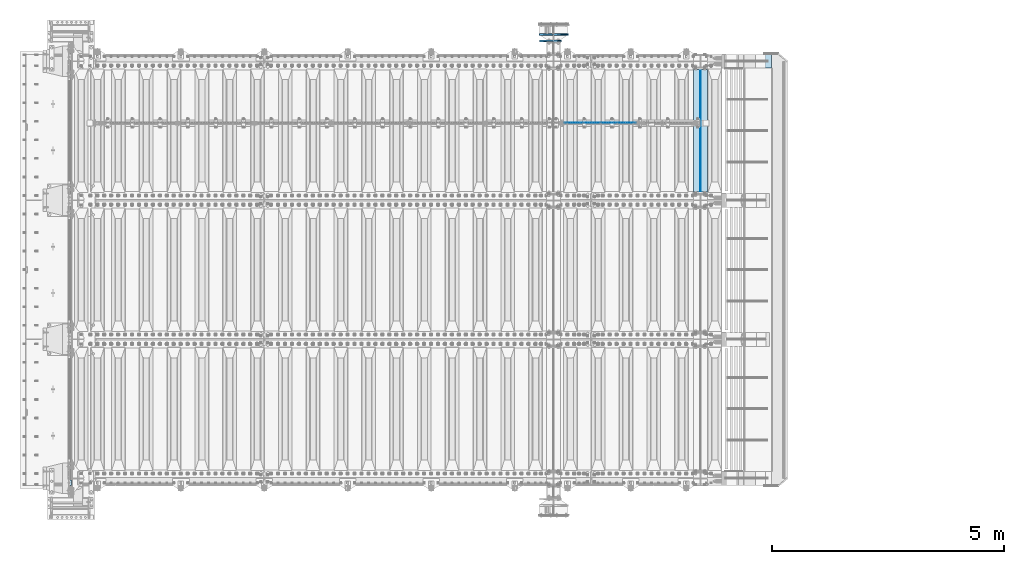
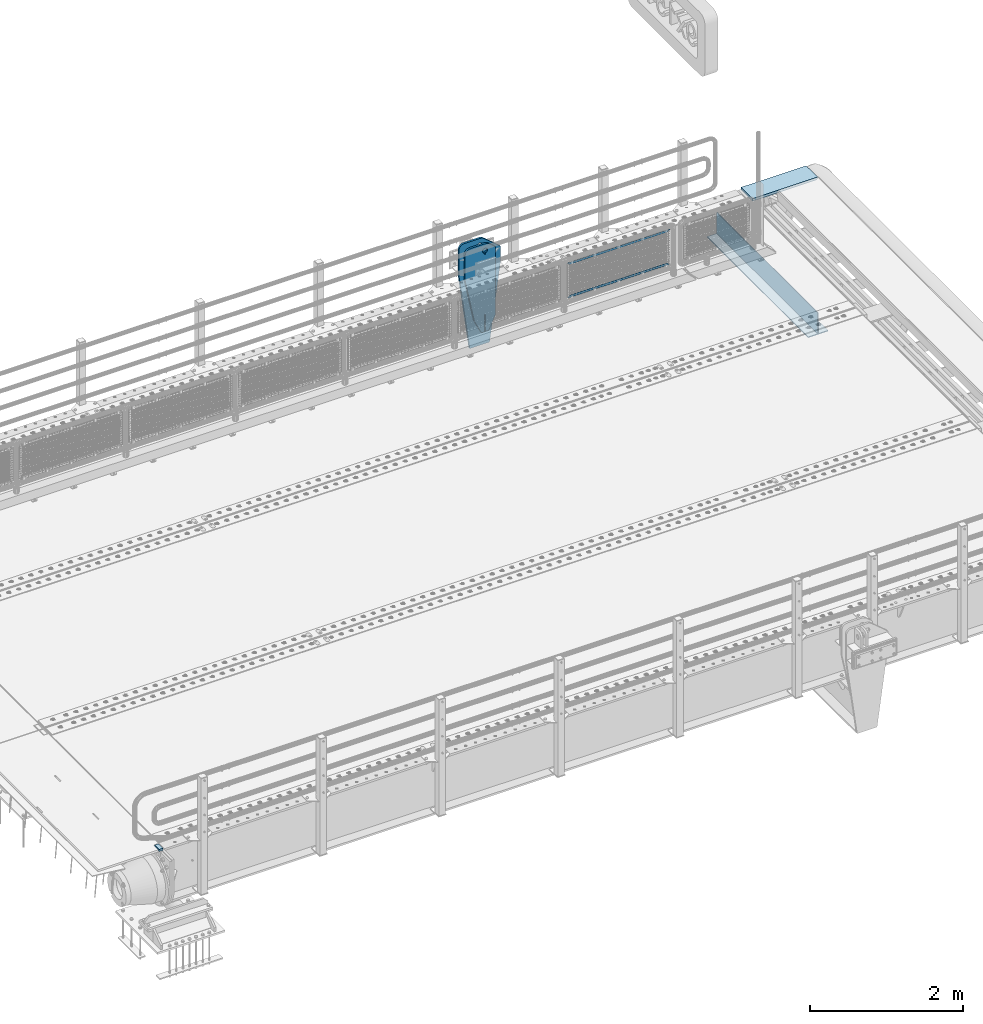
# One storey, part 173 of 219: 8 plates.
"""IFC2X3 building model written with IfcOpenShell, lengths in millimetres."""

from ifc_helpers import new_model, si_unit, frame, origin_with_axes, place, context, subcontext, project, spatial, faceted_brep, material, type_object, element, save


model = new_model("IFC2X3")

# Units and contexts
model_context = context("Model", 3, precision=1e-05, world=origin_with_axes())
body_context = subcontext(model_context, "Body", "Model", "MODEL_VIEW")
ifc_project = project(units=[si_unit("LENGTHUNIT", "METRE", prefix="MILLI"), si_unit("AREAUNIT", "SQUARE_METRE"), si_unit("VOLUMEUNIT", "CUBIC_METRE"), si_unit("MASSUNIT", "GRAM", prefix="KILO"), si_unit("TIMEUNIT", "SECOND"), si_unit("PLANEANGLEUNIT", "RADIAN"), si_unit("SOLIDANGLEUNIT", "STERADIAN"), si_unit("THERMODYNAMICTEMPERATUREUNIT", "DEGREE_CELSIUS"), si_unit("LUMINOUSINTENSITYUNIT", "LUMEN")], contexts=[model_context])

# Site, building, storey
site_placement = place(None, origin_with_axes())
site = spatial("IfcSite", under=ifc_project, at=site_placement, CompositionType="ELEMENT")
building_placement = place(site_placement, origin_with_axes())
building = spatial("IfcBuilding", under=site, at=building_placement, Name="Standard", CompositionType="ELEMENT")
storey_placement = place(building_placement, origin_with_axes())
storey = spatial("IfcBuildingStorey", under=building, at=storey_placement, Name="Undefined", CompositionType="ELEMENT", Elevation=0.0)

# Plates
ifc_material_1 = material()
plate_type_1 = type_object("IfcPlateType", PredefinedType="NOTDEFINED")
plate_1_placement = place(storey_placement, frame((-10.0000000601686, 23910.0000004317, -15.9997806106704), z_axis=(-1.0, 0.0, 0.0), x_axis=(0.0, -4.95099997756316e-06, 0.999999999987744)))
element("IfcPlate", 1, at=plate_1_placement, inside=storey, type_object=plate_type_1, material=ifc_material_1, context=body_context, shape_type="Brep", body=[
    faceted_brep([(0.0, -60.0, 0.0), (-0.000933120085687023, -60.0000000000036, 60.0), (-0.000933120085687023, 59.9999999999964, 60.0), (0.0, 60.0000000000036, 0.0), (24.9991450303709, -60.0, 60.0), (24.9991450303709, 59.9999999999964, 60.0), (26.544215218168, -60.0000000000036, 59.7552873850884), (26.544215218168, 60.0, 59.7552873850884), (27.9380461396139, -60.0000000000036, 59.0451032459123), (27.9380461396139, 60.0, 59.0451032459123), (29.0442025908961, -60.0000000000036, 57.9389639895784), (29.0442025908961, 60.0, 57.9389639895784), (29.7544083969366, -60.0, 56.5451441080361), (29.7544083969366, 60.0000000000036, 56.5451441080361), (29.9991450297669, -60.0000000000036, 55.0000777244568), (29.9991450297669, 60.0, 55.0000777244568), (29.999922274335, -60.0, 5.00007772445704), (29.999922274335, 60.0, 5.00007772445704), (29.7552240705896, -60.0000000000036, 3.45497416452589), (29.7552240705896, 60.0, 3.45497416452589), (29.0450346578116, -60.0, 2.06111146690959), (29.0450346578116, 59.9999999999964, 2.06111146690959), (27.9388736885072, -60.0, 0.954933302319514), (27.9388736885072, 59.9999999999964, 0.954933302319514), (26.5450220308766, -60.0000000000036, 0.244722222183089), (26.5450220308766, 60.0, 0.244722222183089), (24.9999222749392, -60.0, 2.64677169070637e-13), (24.9999222749392, 60.0, 2.66453525910038e-13)], [[[0, 1, 2, 3]], [[1, 4, 5, 2]], [[4, 6, 7, 5]], [[6, 8, 9, 7]], [[8, 10, 11, 9]], [[10, 12, 13, 11]], [[12, 14, 15, 13]], [[14, 16, 17, 15]], [[16, 18, 19, 17]], [[18, 20, 21, 19]], [[20, 22, 23, 21]], [[22, 24, 25, 23]], [[24, 26, 27, 25]], [[26, 0, 3, 27]], [[5, 7, 9, 11, 13, 15, 17, 19, 21, 23, 25, 27, 3, 2]], [[26, 24, 22, 20, 18, 16, 14, 12, 10, 8, 6, 4, 1, 0]]]),
])
ifc_material_2 = material(Name="STEEL/S355N")
plate_type_2 = type_object("IfcPlateType", PredefinedType="NOTDEFINED")
plate_2_placement = place(storey_placement, frame((13555.0, 32825.0, 0.0), z_axis=(0.0, 0.0, -1.0), x_axis=(0.0, -1.0, 0.0)))
element("IfcPlate", 2, at=plate_2_placement, inside=storey, type_object=plate_type_2, material=ifc_material_2, context=body_context, shape_type="Brep", body=[
    faceted_brep([(0.0, -5.0, 0.0), (0.0, -5.0, 336.0), (0.0, 5.0, 336.0), (0.0, 5.0, 0.0), (2650.0, -5.0, 336.0), (2650.0, 5.0, 336.0), (2650.0, -5.0, 0.0), (2650.0, 5.0, 0.0)], [[[0, 1, 2, 3]], [[1, 4, 5, 2]], [[4, 6, 7, 5]], [[6, 0, 3, 7]], [[5, 7, 3, 2]], [[6, 4, 1, 0]]]),
])
plate_type_3 = type_object("IfcPlateType", PredefinedType="NOTDEFINED")
plate_3_placement = place(storey_placement, frame((13405.0, 30175.0, -343.0), z_axis=(0.0, 1.0, 0.0), x_axis=(1.0, 0.0, 0.0)))
element("IfcPlate", 3, at=plate_3_placement, inside=storey, type_object=plate_type_3, material=ifc_material_2, context=body_context, shape_type="Brep", body=[
    faceted_brep([(0.0, -7.0, 0.0), (0.0, -7.0, 2650.0), (0.0, 7.0, 2650.0), (0.0, 7.0, 0.0), (300.0, -7.0, 2650.0), (300.0, 7.0, 2650.0), (300.0, -7.0, 0.0), (300.0, 7.0, 0.0)], [[[0, 1, 2, 3]], [[1, 4, 5, 2]], [[4, 6, 7, 5]], [[6, 0, 3, 7]], [[5, 7, 3, 2]], [[6, 4, 1, 0]]]),
])
ifc_material_3 = material(Name="Misc_Undefined")
plate_type_4 = type_object("IfcPlateType", PredefinedType="NOTDEFINED")
plate_4_placement = place(storey_placement, frame((10622.5050117304, 31670.5, 351.520303374641), z_axis=(0.0, 0.0, 1.0), x_axis=(1.0, 0.0, 0.0)))
element("IfcPlate", 4, at=plate_4_placement, inside=storey, type_object=plate_type_4, material=ifc_material_3, context=body_context, shape_type="Brep", body=[
    faceted_brep([(0.0, -1.5, -5.6843418860808e-14), (35.0002975463885, -1.5, 34.9996948242187), (35.0002975463885, 1.5, 34.9996948242187), (0.0, 1.5, -5.6843418860808e-14), (1515.99035644531, -1.5, 34.9999923706054), (1515.99035644531, 1.5, 34.9999923706054), (1550.98999023438, -1.5, 4.43037606601138e-09), (1550.98999023438, 1.5, 4.43037606601138e-09)], [[[0, 1, 2, 3]], [[1, 4, 5, 2]], [[4, 6, 7, 5]], [[6, 0, 3, 7]], [[5, 7, 3, 2]], [[6, 4, 1, 0]]]),
])
plate_5_placement = place(storey_placement, frame((12173.5000001876, 31670.5, 914.520000175701), z_axis=(-0.707103624179499, 0.0, 0.707109938179501), x_axis=(-0.707109938179508, 0.0, -0.707103624179492)))
element("IfcPlate", 5, at=plate_5_placement, inside=storey, type_object=plate_type_4, material=ifc_material_3, context=body_context, shape_type="Brep", body=[
    faceted_brep([(0.0, -1.5, -5.6843418860808e-14), (1096.72753906249, -1.5, 1096.7177734375), (1096.72753906249, 1.5, 1096.7177734375), (0.0, 1.5, -5.6843418860808e-14), (1096.72045898437, -1.5, 1047.21337890625), (1096.72045898437, 1.5, 1047.21337890625), (49.4976959228516, -1.5, -1.0550138540566e-10), (49.4976959228516, 1.5, -1.0550138540566e-10)], [[[0, 1, 2, 3]], [[1, 4, 5, 2]], [[4, 6, 7, 5]], [[6, 0, 3, 7]], [[5, 7, 3, 2]], [[6, 4, 1, 0]]]),
])
plate_type_5 = type_object("IfcPlateType", PredefinedType="NOTDEFINED")
plate_6_placement = place(storey_placement, frame((14106.9988298905, 33150.0, -10.0000000004865), z_axis=(1.0, 0.0, 0.0), x_axis=(0.0, -1.0, 0.0)))
element("IfcPlate", 6, at=plate_6_placement, inside=storey, type_object=plate_type_5, material=ifc_material_2, context=body_context, shape_type="Brep", body=[
    faceted_brep([(300.0, 7.0, 986.0), (300.0, 20.0, 956.0), (-3.63797880709171e-11, 20.0, 956.0), (-3.63797880709171e-11, 7.0, 986.0), (0.0, 20.0, 0.0), (0.0, -20.0, 0.0), (-3.63797880709171e-11, -20.0, 986.0), (300.0, -20.0, 986.0), (300.0, -20.0, -1.81898940354586e-12), (300.0, 20.0, -1.81898940354586e-12)], [[[0, 1, 2, 3]], [[4, 5, 6, 3, 2]], [[6, 7, 0, 3]], [[7, 8, 9, 1, 0]], [[8, 5, 4, 9]], [[9, 4, 2, 1]], [[8, 7, 6, 5]]]),
])
plate_type_6 = type_object("IfcPlateType", PredefinedType="NOTDEFINED")
plate_7_placement = place(storey_placement, frame((10549.9999999781, 33439.9999999848, -945.000018238371), z_axis=(-0.901283188008788, 0.0, 0.433230441004225), x_axis=(-0.433230441004226, 0.0, -0.901283188008788)))
element("IfcPlate", 7, at=plate_7_placement, inside=storey, type_object=plate_type_6, material=ifc_material_2, context=body_context, shape_type="Brep", body=[
    faceted_brep([(-929.368911797764, -15.0000000000146, 583.252555031777), (-929.368911797764, 14.9999999999854, 583.252555031777), (-937.308302015211, 14.9999999999854, 596.689503306552), (-937.308302015211, -15.0000000000146, 596.689503306552), (-939.501244651427, 14.9999999999854, 612.141897896328), (-939.501244651427, -15.0000000000146, 612.141897896328), (-935.613884069124, 14.9999999999854, 627.257251801118), (-935.613884069124, -15.0000000000146, 627.257251801118), (-926.238035677944, 14.9999999999854, 639.734389409941), (-926.238035677944, -15.0000000000146, 639.734389409941), (-912.801087403169, 14.9999999999854, 647.673779627386), (-912.801087403169, -15.0000000000146, 647.673779627386), (-897.348692813393, 14.9999999999854, 649.866722263603), (-897.348692813393, -15.0000000000146, 649.866722263603), (-882.233338908602, 14.9999999999854, 645.9793616813), (-882.233338908602, -15.0000000000146, 645.9793616813), (-869.756201299781, 14.9999999999854, 636.603513290122), (-869.756201299781, -15.0000000000146, 636.603513290122), (-861.816811082334, 14.9999999999854, 623.166565015345), (-861.816811082334, -15.0000000000146, 623.166565015345), (-859.623868446117, 14.9999999999854, 607.71417042557), (-859.623868446117, -15.0000000000146, 607.71417042557), (-863.511229028421, 14.9999999999854, 592.59881652078), (-863.511229028421, -15.0000000000146, 592.59881652078), (-872.8870774196, 14.9999999999854, 580.121678911957), (-872.8870774196, -15.0000000000146, 580.121678911957), (-886.324025694375, 14.9999999999854, 572.18228869451), (-886.324025694375, -15.0000000000146, 572.18228869451), (-901.776420284152, 14.9999999999854, 569.989346058295), (-901.776420284152, -15.0000000000146, 569.989346058295), (-916.891774188941, 14.9999999999854, 573.876706640596), (-916.891774188941, -15.0000000000146, 573.876706640596), (264.349945992725, -15.0, 42.1349880554844), (264.349945992725, 15.0, 42.1349880554844), (15.5957837433803, 14.9999999999927, 161.70659090654), (15.5957837433803, -15.0000000000073, 161.70659090654), (244.096420288085, -15.0, -9.27684595808387e-11), (244.096420288085, 15.0, -9.27684595808387e-11), (0.0, -15.0, 0.0), (0.0, 15.0, 0.0), (-976.801696777345, -15.0, 469.530822753904), (-976.801696777345, 15.0, 469.530822753904), (-1005.61097945758, -15.0, 584.572341407271), (-1005.61097945758, 15.0, 584.572341407271), (-1008.62086606962, -15.0, 603.379087420499), (-1008.62086606962, 15.0, 603.379087420499), (-1008.34154488138, -15.0, 622.423117789542), (-1008.34154488138, 15.0, 622.423117789542), (-1004.7813898293, -15.0, 641.133500175491), (-1004.7813898293, 15.0, 641.133500175491), (-998.047132923921, -15.0, 658.949304871176), (-998.047132923921, 15.0, 658.949304871176), (-903.392995239111, -15.0, 855.865677422373), (-903.392995239111, 15.0, 855.865677422373), (-891.965893301481, -15.0, 873.346258360982), (-891.965893301481, 15.0, 873.346258360982), (-876.403853384478, -15.0, 887.273651594001), (-876.403853384478, 15.0, 887.273651594001), (-857.767402657623, -15.0, 896.698728408075), (-857.767402657623, 15.0, 896.698728408075), (-837.326584280025, -15.0, 900.979185474775), (-837.326584280025, 15.0, 900.979185474775), (-816.474406068874, -15.0, 899.823316755488), (-816.474406068874, 15.0, 899.823316755488), (-796.631909330706, -15.0, 893.309892783487), (-796.631909330706, 15.0, 893.309892783487), (-427.105804443361, -15.0, 715.685424804686), (-427.105804443361, 15.0, 715.685424804686), (138.633743286132, -15.0, 288.410614013672), (138.633743286132, 15.0, 288.410614013672), (291.101928710937, -15.0, 97.7892227172852), (291.101928710937, 15.0, 97.7892227172852), (270.848403405487, -15.0, 55.6542354921748), (270.848403405487, 15.0, 55.6542354921748), (22.0942403584436, -15.0000000000073, 175.225838726672), (22.0942403584436, 14.9999999999927, 175.225838726672), (-855.850321908049, -15.0, 588.916357796496), (-852.143242449833, -15.0, 592.234043568264), (-847.175983319465, -15.0, 591.958700652023), (-843.858297547697, -15.0, 588.251621193805), (-844.133640463935, -15.0, 583.284362063439), (-847.840719922153, -15.0, 579.96667629167), (-852.80797905252, -15.0, 580.24201920791), (-856.125664824289, -15.0, 583.949098666128), (-844.133640463935, 15.0, 583.284362063439), (-847.840719922153, 15.0, 579.96667629167), (-843.858297547697, 15.0, 588.251621193805), (-847.175983319465, 15.0, 591.958700652023), (-852.143242449833, 15.0, 592.234043568264), (-855.850321908049, 15.0, 588.916357796496), (-856.125664824289, 15.0, 583.949098666128), (-852.80797905252, 15.0, 580.24201920791)], [[[0, 1, 2, 3]], [[3, 2, 4, 5]], [[5, 4, 6, 7]], [[7, 6, 8, 9]], [[9, 8, 10, 11]], [[11, 10, 12, 13]], [[13, 12, 14, 15]], [[15, 14, 16, 17]], [[17, 16, 18, 19]], [[19, 18, 20, 21]], [[21, 20, 22, 23]], [[23, 22, 24, 25]], [[25, 24, 26, 27]], [[27, 26, 28, 29]], [[29, 28, 30, 31]], [[31, 30, 1, 0]], [[32, 33, 34, 35]], [[36, 37, 33, 32]], [[36, 38, 39, 37]], [[38, 40, 41, 39]], [[40, 42, 43, 41]], [[42, 44, 45, 43]], [[44, 46, 47, 45]], [[46, 48, 49, 47]], [[48, 50, 51, 49]], [[50, 52, 53, 51]], [[52, 54, 55, 53]], [[54, 56, 57, 55]], [[56, 58, 59, 57]], [[58, 60, 61, 59]], [[60, 62, 63, 61]], [[62, 64, 65, 63]], [[64, 66, 67, 65]], [[66, 68, 69, 67]], [[68, 70, 71, 69]], [[71, 70, 72, 73]], [[74, 75, 73, 72]], [[35, 34, 75, 74]], [[72, 70, 68, 66, 64, 62, 60, 58, 56, 54, 52, 50, 48, 46, 44, 42, 40, 38, 36, 32, 35, 74], [3, 5, 7, 9, 11, 13, 15, 17, 19, 21, 23, 25, 27, 29, 31, 0], [76, 77, 78, 79, 80, 81, 82, 83]], [[80, 84, 85, 81]], [[79, 86, 84, 80]], [[78, 87, 86, 79]], [[77, 88, 87, 78]], [[76, 89, 88, 77]], [[83, 90, 89, 76]], [[82, 91, 90, 83]], [[81, 85, 91, 82]], [[37, 39, 41, 43, 45, 47, 49, 51, 53, 55, 57, 59, 61, 63, 65, 67, 69, 71, 73, 75, 34, 33], [26, 24, 22, 20, 18, 16, 14, 12, 10, 8, 6, 4, 2, 1, 30, 28], [84, 86, 87, 88, 89, 90, 91, 85]]]),
])
plate_type_7 = type_object("IfcPlateType", PredefinedType="NOTDEFINED")
plate_8_placement = place(storey_placement, frame((10539.9999999781, 33579.9999999848, -1470.00001823837), z_axis=(0.0, 0.0, 1.0), x_axis=(-1.0, 0.0, 0.0)))
element("IfcPlate", 8, at=plate_8_placement, inside=storey, type_object=plate_type_7, material=ifc_material_2, context=body_context, shape_type="Brep", body=[
    faceted_brep([(145.403805922693, -15.0000000000073, 1549.59619407771), (145.403805922693, 14.9999999999927, 1549.59619407771), (150.000000000406, 14.9999999999927, 1551.5), (150.000000000406, -15.0000000000073, 1551.5), (154.596194078118, 14.9999999999927, 1549.59619407771), (154.596194078118, -15.0000000000073, 1549.59619407771), (156.500000000406, 14.9999999999927, 1545.0), (156.500000000406, -15.0000000000073, 1545.0), (154.596194078118, 14.9999999999927, 1540.40380592229), (154.596194078118, -15.0000000000073, 1540.40380592229), (150.000000000406, 14.9999999999927, 1538.5), (150.000000000406, -15.0000000000073, 1538.5), (145.403805922693, 14.9999999999927, 1540.40380592229), (145.403805922693, -15.0000000000073, 1540.40380592229), (143.500000000406, 14.9999999999927, 1545.0), (143.500000000406, -15.0000000000073, 1545.0), (300.0, -15.0, 0.0), (0.0, -15.0, 0.0), (0.0, 15.0, 0.0), (300.0, 15.0, 0.0), (462.5, -15.0, 1210.0), (462.5, 15.0, 1210.0), (462.5, -15.0, 1630.0), (462.5, 15.0, 1630.0), (459.774066103126, -15.0, 1650.7055236082), (459.774066103126, 15.0, 1650.7055236082), (451.782032302755, -15.0, 1670.0), (451.782032302755, 15.0, 1670.0), (439.068542494924, -15.0, 1686.56854249492), (439.068542494924, 15.0, 1686.56854249492), (422.5, -15.0, 1699.28203230276), (422.5, 15.0, 1699.28203230276), (403.205523608201, -15.0, 1707.27406610313), (403.205523608201, 15.0, 1707.27406610313), (382.5, -15.0, 1710.0), (382.5, 15.0, 1710.0), (151.788081037079, -15.0, 1710.0), (151.788081037079, 15.0, 1710.0), (132.694887325031, -15.0, 1708.33028179541), (132.694887325031, 15.0, 1708.33028179541), (114.181334578885, -15.0, 1703.37181734316), (114.181334578885, 15.0, 1703.37181734316), (96.8094667268542, -15.0, 1695.27513824985), (96.8094667268542, 15.0, 1695.27513824985), (81.1066678416755, -15.0, 1684.28604765144), (81.1066678416755, 15.0, 1684.28604765144), (-162.5, -15.0, 1480.0), (-162.5, 15.0, 1480.0), (-162.5, -15.0, 1210.0), (-162.5, 15.0, 1210.0), (121.715728752944, -15.0, 1628.28427124746), (134.692662705802, -15.0, 1636.95518130045), (150.000000000406, -15.0, 1640.0), (165.307337295009, -15.0, 1636.95518130045), (178.284271247867, -15.0, 1628.28427124746), (186.955181300857, -15.0, 1615.3073372946), (190.000000000406, -15.0, 1600.0), (186.955181300857, -15.0, 1584.6926627054), (178.284271247867, -15.0, 1571.71572875254), (165.307337295009, -15.0, 1563.04481869955), (150.000000000406, -15.0, 1560.0), (134.692662705802, -15.0, 1563.04481869955), (121.715728752944, -15.0, 1571.71572875254), (113.044818699955, -15.0, 1584.6926627054), (110.000000000406, -15.0, 1600.0), (113.044818699955, -15.0, 1615.3073372946), (121.715728752944, 14.9999999999527, 1571.71572875254), (113.044818699955, 14.9999999999527, 1584.6926627054), (134.692662705802, 14.9999999999527, 1563.04481869955), (150.000000000406, 14.9999999999527, 1560.0), (165.307337295009, 14.9999999999527, 1563.04481869955), (178.284271247867, 14.9999999999527, 1571.71572875254), (186.955181300857, 14.9999999999527, 1584.6926627054), (190.000000000406, 14.9999999999527, 1600.0), (186.955181300857, 14.9999999999527, 1615.3073372946), (178.284271247867, 14.9999999999527, 1628.28427124746), (165.307337295009, 14.9999999999527, 1636.95518130045), (150.000000000406, 14.9999999999527, 1640.0), (134.692662705802, 14.9999999999527, 1636.95518130045), (121.715728752944, 14.9999999999527, 1628.28427124746), (113.044818699955, 14.9999999999527, 1615.3073372946), (110.000000000406, 14.9999999999527, 1600.0)], [[[0, 1, 2, 3]], [[3, 2, 4, 5]], [[5, 4, 6, 7]], [[7, 6, 8, 9]], [[9, 8, 10, 11]], [[11, 10, 12, 13]], [[13, 12, 14, 15]], [[15, 14, 1, 0]], [[16, 17, 18, 19]], [[20, 16, 19, 21]], [[22, 20, 21, 23]], [[24, 22, 23, 25]], [[26, 24, 25, 27]], [[28, 26, 27, 29]], [[30, 28, 29, 31]], [[32, 30, 31, 33]], [[34, 32, 33, 35]], [[36, 34, 35, 37]], [[38, 36, 37, 39]], [[40, 38, 39, 41]], [[42, 40, 41, 43]], [[44, 42, 43, 45]], [[46, 44, 45, 47]], [[48, 46, 47, 49]], [[17, 48, 49, 18]], [[16, 20, 22, 24, 26, 28, 30, 32, 34, 36, 38, 40, 42, 44, 46, 48, 17], [3, 5, 7, 9, 11, 13, 15, 0], [50, 51, 52, 53, 54, 55, 56, 57, 58, 59, 60, 61, 62, 63, 64, 65]], [[62, 66, 67, 63]], [[61, 68, 66, 62]], [[60, 69, 68, 61]], [[59, 70, 69, 60]], [[58, 71, 70, 59]], [[57, 72, 71, 58]], [[56, 73, 72, 57]], [[55, 74, 73, 56]], [[54, 75, 74, 55]], [[53, 76, 75, 54]], [[52, 77, 76, 53]], [[51, 78, 77, 52]], [[50, 79, 78, 51]], [[65, 80, 79, 50]], [[64, 81, 80, 65]], [[63, 67, 81, 64]], [[47, 45, 43, 41, 39, 37, 35, 33, 31, 29, 27, 25, 23, 21, 19, 18, 49], [10, 8, 6, 4, 2, 1, 14, 12], [66, 68, 69, 70, 71, 72, 73, 74, 75, 76, 77, 78, 79, 80, 81, 67]]]),
])

save(model, "model.ifc")
